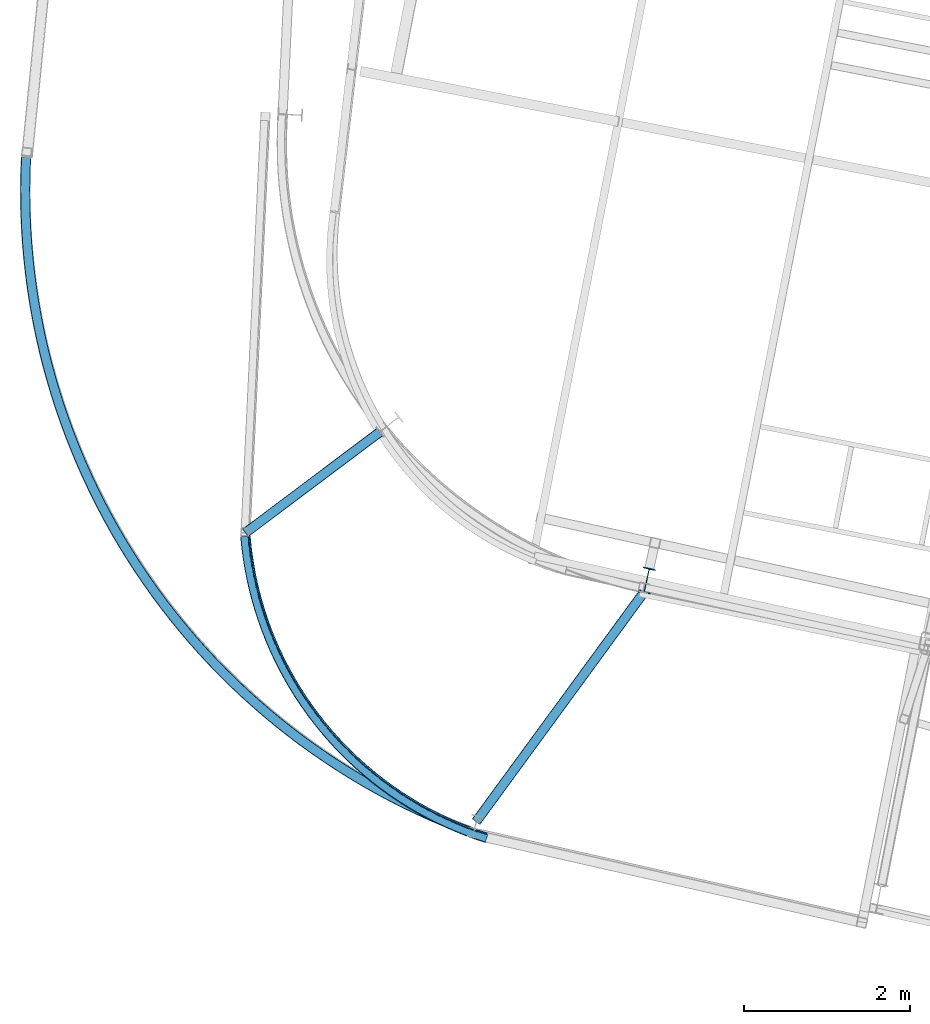
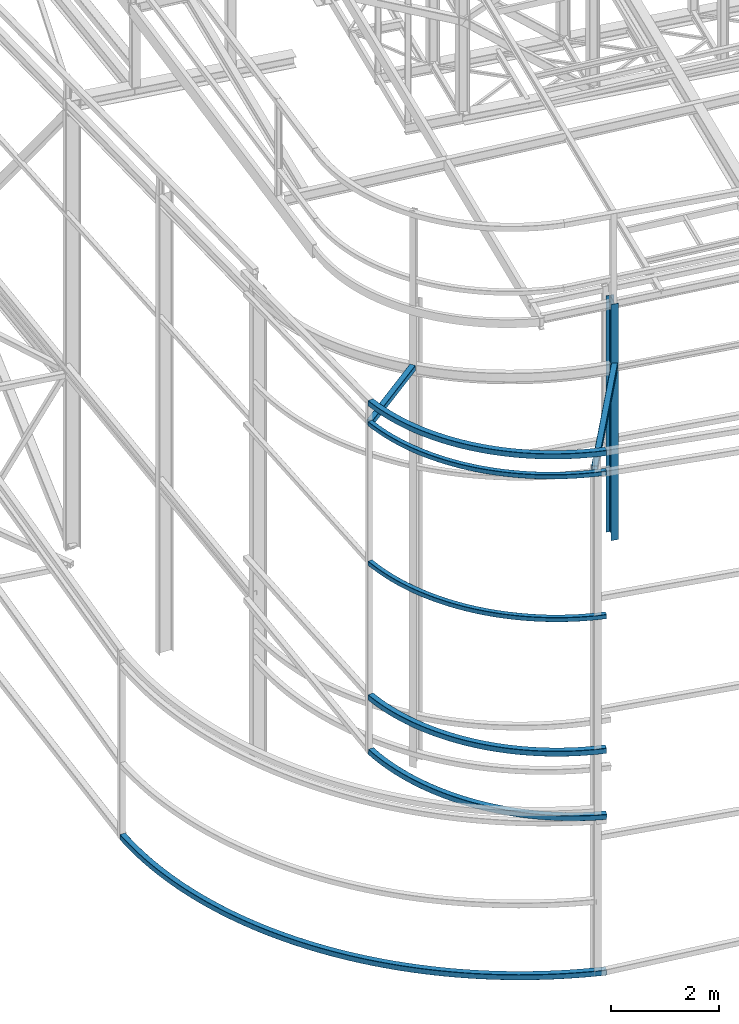
# One storey, part 17 of 215: 9 beams, 9 elements without a shape of their own.
"""IFC2X3 building model written with IfcOpenShell, lengths in millimetres."""

from ifc_helpers import new_model, entity, si_unit, frame, origin_with_axes, origin_2d_with_axis, place, context, subcontext, project, spatial, hollow_rectangle, i_section, extrude, material, type_object, element, aggregate, save


model = new_model("IFC2X3")

# Units and contexts
model_context = context("Model", 3, precision=1e-05, world=origin_with_axes())
body_context = subcontext(model_context, "Body", "Model", "MODEL_VIEW")
ifc_project = project(units=[si_unit("LENGTHUNIT", "METRE", prefix="MILLI"), si_unit("AREAUNIT", "SQUARE_METRE"), si_unit("VOLUMEUNIT", "CUBIC_METRE"), si_unit("MASSUNIT", "GRAM", prefix="KILO"), si_unit("TIMEUNIT", "SECOND"), si_unit("PLANEANGLEUNIT", "RADIAN"), si_unit("SOLIDANGLEUNIT", "STERADIAN"), si_unit("THERMODYNAMICTEMPERATUREUNIT", "DEGREE_CELSIUS"), si_unit("LUMINOUSINTENSITYUNIT", "LUMEN")], contexts=[model_context])

# Site, building, storey
site_placement = place(None, origin_with_axes())
site = spatial("IfcSite", under=ifc_project, at=site_placement, CompositionType="ELEMENT")
building_placement = place(site_placement, origin_with_axes())
building = spatial("IfcBuilding", under=site, at=building_placement, Name="Undefined", CompositionType="ELEMENT")
storey_placement = place(building_placement, origin_with_axes())
storey = spatial("IfcBuildingStorey", under=building, at=storey_placement, Name="Undefined", CompositionType="ELEMENT", Elevation=0.0)

# Assembly, beam
assembly_1_placement = place(storey_placement, origin_with_axes())
assembly_1 = element("IfcElementAssembly", 1, at=assembly_1_placement, inside=storey, Name="Steel Assembly", AssemblyPlace="NOTDEFINED", PredefinedType="RIGID_FRAME")
ifc_material = material(Name="STEEL/S275JR")
beam_type_1 = type_object("IfcBeamType", PredefinedType="NOTDEFINED")
beam_1_placement = place(assembly_1_placement, frame((39709.1318228131, 7834.46412800681, 11320.2537005512), z_axis=(-0.0010520360002914, 0.0211525970058401, 0.99977570527602), x_axis=(-0.625284034967556, 0.780208455959516, -0.0171651059991092)))
beam_1 = element("IfcBeam", 2, at=beam_1_placement, type_object=beam_type_1, material=ifc_material, Name="LISSE", context=body_context, shape_type="SweptSolid", body=[
    entity("IfcRevolvedAreaSolid", entity("IfcRectangleHollowProfileDef", "AREA", None, entity("IfcAxis2Placement2D", entity("IfcCartesianPoint", [0.0, 0.0]), entity("IfcDirection", [1.0, 0.0])), 120.0, 120.0, 4.0, 4.0, 8.0), entity("IfcAxis2Placement3D", entity("IfcCartesianPoint", [4659.88879201379, 5.78989173841117e-13, 0.0]), entity("IfcDirection", [-0.831133689553529, 0.556072648211669, 0.0]), entity("IfcDirection", [-0.556072648211669, -0.831133689553529, 0.0])), entity("IfcAxis1Placement", entity("IfcCartesianPoint", [4190.0, 0.0, 0.0]), entity("IfcDirection", [0.0, 1.0, 0.0])), 1.17930598845958),
])
aggregate(assembly_1, [beam_1])

assembly_2_placement = place(storey_placement, origin_with_axes())
assembly_2 = element("IfcElementAssembly", 3, at=assembly_2_placement, inside=storey, Name="Steel Assembly", AssemblyPlace="NOTDEFINED", PredefinedType="RIGID_FRAME")
beam_type_2 = type_object("IfcBeamType", PredefinedType="NOTDEFINED")
beam_2_placement = place(assembly_2_placement, frame((36796.661787344, 11515.5688427175, 10751.5727496122), z_axis=(-0.600137651264968, 0.799895391353167, 0.00147051900064968), x_axis=(0.799579451903445, 0.599950357927552, -0.0270604529967319)))
beam_2 = element("IfcBeam", 4, at=beam_2_placement, type_object=beam_type_2, material=ifc_material, context=body_context, shape_type="SweptSolid", body=[
    extrude(hollow_rectangle(XDim=120.0, YDim=120.0, WallThickness=5.0, InnerFilletRadius=5.0, OuterFilletRadius=10.0, at=origin_2d_with_axis()), frame((2024.71053237873, 0.0, -3.74916546209729e-12), z_axis=(-1.0, 0.0, 0.0), x_axis=(-6.93889390390723e-18, -1.0, -3.46944695195361e-18)), (0.0, 0.0, 1.0), 2024.7),
])
aggregate(assembly_2, [beam_2])

assembly_3_placement = place(storey_placement, origin_with_axes())
assembly_3 = element("IfcElementAssembly", 5, at=assembly_3_placement, inside=storey, Name="Steel Assembly", AssemblyPlace="NOTDEFINED", PredefinedType="RIGID_FRAME")
beam_3_placement = place(assembly_3_placement, frame((39579.7315329028, 8028.61051774406, 10858.770352861), z_axis=(-0.807016070297301, 0.59052947621755, 3.57000000935482e-07), x_axis=(0.590433000146976, 0.806884237200855, -0.0180748470044993)))
beam_3 = element("IfcBeam", 6, at=beam_3_placement, type_object=beam_type_2, material=ifc_material, context=body_context, shape_type="SweptSolid", body=[
    extrude(hollow_rectangle(XDim=120.0, YDim=120.0, WallThickness=5.0, InnerFilletRadius=5.0, OuterFilletRadius=10.0, at=origin_2d_with_axis()), frame((3430.16845390416, 1.81898940354586e-12, 3.62799944889922e-12), z_axis=(-1.0, 0.0, 0.0), x_axis=(-6.93889390390723e-18, -1.0, -3.46944695195361e-18)), (0.0, 0.0, 1.0), 3430.2),
])
aggregate(assembly_3, [beam_3])

assembly_4_placement = place(storey_placement, origin_with_axes())
assembly_4 = element("IfcElementAssembly", 7, at=assembly_4_placement, inside=storey, Name="Steel Assembly", AssemblyPlace="NOTDEFINED", PredefinedType="RIGID_FRAME")
beam_4_placement = place(assembly_4_placement, frame((39710.4190762422, 7835.30165930923, -390.000200053562), z_axis=(0.0, 0.0, 1.0), x_axis=(-0.560747221918006, 0.827987048878929, 0.0)))
beam_4 = element("IfcBeam", 8, at=beam_4_placement, type_object=beam_type_2, material=ifc_material, Name="LISSE", context=body_context, shape_type="SweptSolid", body=[
    entity("IfcRevolvedAreaSolid", entity("IfcRectangleHollowProfileDef", "AREA", None, entity("IfcAxis2Placement2D", entity("IfcCartesianPoint", [0.0, 0.0]), entity("IfcDirection", [1.0, 0.0])), 120.0, 120.0, 5.0, 5.0, 10.0), entity("IfcAxis2Placement3D", entity("IfcCartesianPoint", [9918.05292387863, 1.10112507155409e-12, 5.6843418860808e-14]), entity("IfcDirection", [-0.79862904704503, 0.601823599749917, 0.0]), entity("IfcDirection", [-0.601823599749917, -0.79862904704503, 0.0])), entity("IfcAxis1Placement", entity("IfcCartesianPoint", [8240.0, 0.0, 0.0]), entity("IfcDirection", [0.0, 1.0, 0.0])), 1.29156512469074),
])
aggregate(assembly_4, [beam_4])

assembly_5_placement = place(storey_placement, origin_with_axes())
assembly_5 = element("IfcElementAssembly", 9, at=assembly_5_placement, inside=storey, Name="Steel Assembly", AssemblyPlace="NOTDEFINED", PredefinedType="RIGID_FRAME")
beam_5_placement = place(assembly_5_placement, frame((36796.7255203266, 11469.5156203607, 3381.99591114415), z_axis=(-0.0350413860047427, 0.0437226360059217, -0.998428982135214), x_axis=(0.624400909911712, -0.77909173788984, -0.0560318449920773)))
beam_5 = element("IfcBeam", 10, at=beam_5_placement, type_object=beam_type_2, material=ifc_material, Name="LISSE", context=body_context, shape_type="SweptSolid", body=[
    entity("IfcRevolvedAreaSolid", entity("IfcRectangleHollowProfileDef", "AREA", None, entity("IfcAxis2Placement2D", entity("IfcCartesianPoint", [0.0, 0.0]), entity("IfcDirection", [1.0, 0.0])), 120.0, 120.0, 5.0, 5.0, 10.0), entity("IfcAxis2Placement3D", entity("IfcCartesianPoint", [4667.49276838124, 2.03031767216078e-13, 0.0]), entity("IfcDirection", [-0.830525875954982, 0.556980043959575, -6.22831699294277e-18]), entity("IfcDirection", [-0.556980043959575, -0.830525875954982, 9.28718808220806e-18])), entity("IfcAxis1Placement", entity("IfcCartesianPoint", [4190.0, 0.0, 0.0]), entity("IfcDirection", [0.0, 1.0, 0.0])), 1.18149030028023),
])
aggregate(assembly_5, [beam_5])

assembly_6_placement = place(storey_placement, origin_with_axes())
assembly_6 = element("IfcElementAssembly", 11, at=assembly_6_placement, inside=storey, Name="Steel Assembly", AssemblyPlace="NOTDEFINED", PredefinedType="RIGID_FRAME")
beam_6_placement = place(assembly_6_placement, frame((36794.8364095005, 11472.2659398891, 4609.93969486328), z_axis=(2.84100000084927e-05, 2.28810000084372e-05, -0.999999999334666), x_axis=(0.62534875301968, -0.780345396024557, -8.90000000074199e-08)))
beam_6 = element("IfcBeam", 12, at=beam_6_placement, type_object=beam_type_2, material=ifc_material, Name="LISSE", context=body_context, shape_type="SweptSolid", body=[
    entity("IfcRevolvedAreaSolid", entity("IfcRectangleHollowProfileDef", "AREA", None, entity("IfcAxis2Placement2D", entity("IfcCartesianPoint", [0.0, 0.0]), entity("IfcDirection", [1.0, 0.0])), 120.0, 120.0, 5.0, 5.0, 10.0), entity("IfcAxis2Placement3D", entity("IfcCartesianPoint", [4660.12814124773, 7.23718885314011e-12, -1.17801699397841e-17]), entity("IfcDirection", [-0.831114579371816, 0.55610121017276, 2.10094458514412e-21]), entity("IfcDirection", [-0.55610121017276, -0.831114579371816, 1.40574820283819e-21])), entity("IfcAxis1Placement", entity("IfcCartesianPoint", [4190.0, 0.0, 0.0]), entity("IfcDirection", [0.0, 1.0, 0.0])), 1.1793747193745),
])
aggregate(assembly_6, [beam_6])

assembly_7_placement = place(storey_placement, origin_with_axes())
assembly_7 = element("IfcElementAssembly", 13, at=assembly_7_placement, inside=storey, Name="Steel Assembly", AssemblyPlace="NOTDEFINED", PredefinedType="RIGID_FRAME")
beam_type_3 = type_object("IfcBeamType", PredefinedType="NOTDEFINED")
beam_7_placement = place(assembly_7_placement, frame((36785.3781792727, 11470.5352695551, 10777.3911214956), z_axis=(0.0120011529982056, -0.015023329997757, -0.999815118850726), x_axis=(0.625257186122428, -0.780181853152764, 0.0192282920037649)))
beam_7 = element("IfcBeam", 14, at=beam_7_placement, type_object=beam_type_3, material=ifc_material, Name="LISSE", context=body_context, shape_type="SweptSolid", body=[
    entity("IfcRevolvedAreaSolid", entity("IfcRectangleHollowProfileDef", "AREA", None, entity("IfcAxis2Placement2D", entity("IfcCartesianPoint", [0.0, 0.0]), entity("IfcDirection", [1.0, 0.0])), 100.0, 100.0, 5.0, 5.0, 10.0), entity("IfcAxis2Placement3D", entity("IfcCartesianPoint", [4672.07747030325, -2.33606520876183e-13, 1.81898940354586e-12]), entity("IfcDirection", [-0.831048671862266, 0.556199698845625, 6.38838001557522e-19]), entity("IfcDirection", [-0.556199698845625, -0.831048671862266, -9.54523121518046e-19])), entity("IfcAxis1Placement", entity("IfcCartesianPoint", [4200.0, 0.0, 0.0]), entity("IfcDirection", [0.0, 1.0, 0.0])), 1.17961173261054),
])
aggregate(assembly_7, [beam_7])

assembly_8_placement = place(storey_placement, origin_with_axes())
assembly_8 = element("IfcElementAssembly", 15, at=assembly_8_placement, inside=storey, Name="Steel Assembly", AssemblyPlace="NOTDEFINED", PredefinedType="RIGID_FRAME")
beam_8_placement = place(assembly_8_placement, frame((36784.6810360201, 11471.3135827978, 7631.87210969346), z_axis=(2.84100000084927e-05, 2.28810000084372e-05, -0.999999999334666), x_axis=(0.625383386990381, -0.780317639987998, 0.0)))
beam_8 = element("IfcBeam", 16, at=beam_8_placement, type_object=beam_type_3, material=ifc_material, Name="LISSE", context=body_context, shape_type="SweptSolid", body=[
    entity("IfcRevolvedAreaSolid", entity("IfcRectangleHollowProfileDef", "AREA", None, entity("IfcAxis2Placement2D", entity("IfcCartesianPoint", [0.0, 0.0]), entity("IfcDirection", [1.0, 0.0])), 100.0, 100.0, 5.0, 5.0, 10.0), entity("IfcAxis2Placement3D", entity("IfcCartesianPoint", [4671.29453493564, 7.77926812123681e-13, 9.09478874811419e-13]), entity("IfcDirection", [-0.831111045091258, 0.556106492254242, 2.815913752077e-21]), entity("IfcDirection", [-0.556106492254242, -0.831111045091258, 1.88416208448545e-21])), entity("IfcAxis1Placement", entity("IfcCartesianPoint", [4200.0, 0.0, 0.0]), entity("IfcDirection", [0.0, 1.0, 0.0])), 1.17938743023975),
])
aggregate(assembly_8, [beam_8])

assembly_9_placement = place(storey_placement, origin_with_axes())
assembly_9 = element("IfcElementAssembly", 17, at=assembly_9_placement, inside=storey, Name="Steel Assembly", AssemblyPlace="NOTDEFINED", PredefinedType="RIGID_FRAME")
beam_type_4 = type_object("IfcBeamType", Name="IPE300", PredefinedType="NOTDEFINED")
beam_9_placement = place(assembly_9_placement, frame((41639.7643950578, 10940.7762013975, 12184.3138660628), z_axis=(0.214537767913723, 0.976715693607202, 1.00000033813359e-09), x_axis=(0.0, 0.0, -1.0)))
beam_9 = element("IfcBeam", 18, at=beam_9_placement, type_object=beam_type_4, material=ifc_material, Name="MONTANT", ObjectType="IPE300", context=body_context, shape_type="SweptSolid", body=[
    extrude(i_section(OverallWidth=150.0, OverallDepth=300.0, WebThickness=7.099999905, FlangeThickness=10.69999981, FilletRadius=15.0, at=origin_2d_with_axis()), frame((5324.31459257732, -1.10104245152828e-21, -3.63797880764223e-12), z_axis=(-1.0, 0.0, 0.0), x_axis=(-6.93889390390723e-18, -1.0, -3.46944695195361e-18)), (0.0, 0.0, 1.0), 5324.3),
])
aggregate(assembly_9, [beam_9])

save(model, "model.ifc")
